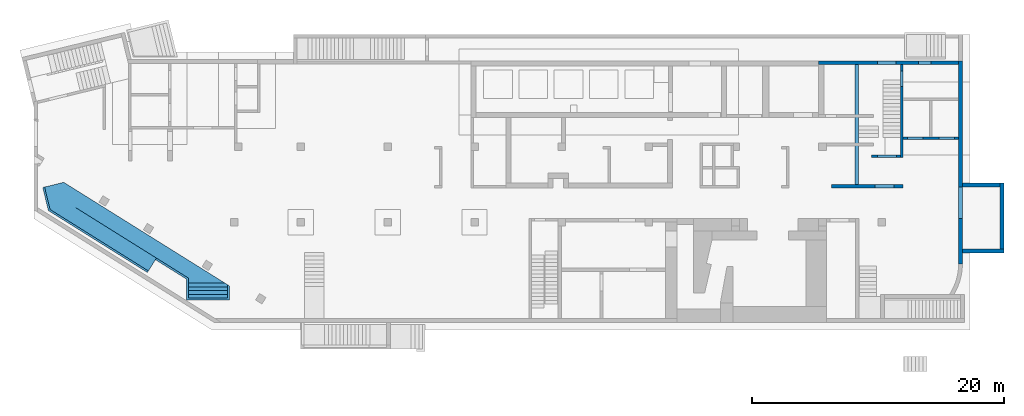
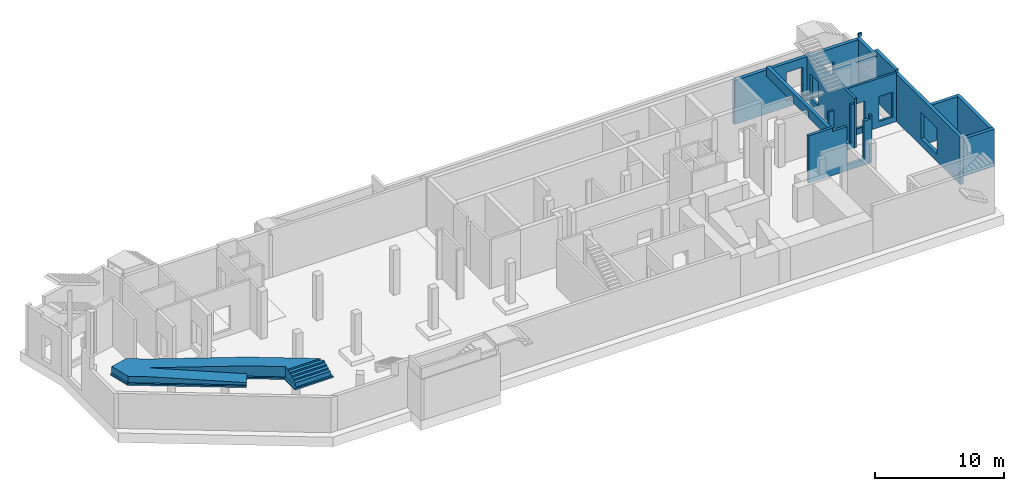
# One storey, part 8 of 9: 10 walls, 1 stair, 6 openings.
"""IFC4 building model written with IfcOpenShell, lengths in millimetres."""

from ifc_helpers import new_model, entity, si_unit, converted_unit, derived_unit, direction, frame, origin, place, context, subcontext, project, spatial, indexed_curve, outline, extrude, polygons, material, type_object, element, save


model = new_model("IFC4")

# Units and contexts
model_context = context("Model", 3, precision=0.01, world=origin(), true_north=direction((6.12303176911189e-17, 1.0)))
plan_context = context("Plan", 3, precision=0.01, world=origin(), true_north=direction((6.12303176911189e-17, 1.0)))
body_context = subcontext(model_context, "Body", "Model", "MODEL_VIEW")
ifc_project = project(units=[si_unit("LENGTHUNIT", "METRE", prefix="MILLI"), si_unit("AREAUNIT", "SQUARE_METRE"), si_unit("VOLUMEUNIT", "CUBIC_METRE"), converted_unit("PLANEANGLEUNIT", "DEGREE", entity("IfcRatioMeasure", 0.0174532925199433), si_unit("PLANEANGLEUNIT", "RADIAN"), dimensions=[0, 0, 0, 0, 0, 0, 0]), si_unit("MASSUNIT", "GRAM", prefix="KILO"), derived_unit("MASSDENSITYUNIT", [(si_unit("MASSUNIT", "GRAM", prefix="KILO"), 1), (si_unit("LENGTHUNIT", "METRE"), -3)]), derived_unit("MOMENTOFINERTIAUNIT", [(si_unit("LENGTHUNIT", "METRE"), 4)]), si_unit("TIMEUNIT", "SECOND"), si_unit("FREQUENCYUNIT", "HERTZ"), si_unit("THERMODYNAMICTEMPERATUREUNIT", "DEGREE_CELSIUS"), derived_unit("THERMALTRANSMITTANCEUNIT", [(si_unit("MASSUNIT", "GRAM", prefix="KILO"), 1), (si_unit("THERMODYNAMICTEMPERATUREUNIT", "KELVIN"), -1), (si_unit("TIMEUNIT", "SECOND"), -3)]), derived_unit("VOLUMETRICFLOWRATEUNIT", [(si_unit("LENGTHUNIT", "METRE"), 3), (si_unit("TIMEUNIT", "SECOND"), -1)]), derived_unit("MASSFLOWRATEUNIT", [(si_unit("MASSUNIT", "GRAM", prefix="KILO"), 1), (si_unit("TIMEUNIT", "SECOND"), -1)]), derived_unit("ROTATIONALFREQUENCYUNIT", [(si_unit("TIMEUNIT", "SECOND"), -1)]), si_unit("ELECTRICCURRENTUNIT", "AMPERE"), si_unit("ELECTRICVOLTAGEUNIT", "VOLT"), si_unit("POWERUNIT", "WATT"), si_unit("FORCEUNIT", "NEWTON", prefix="KILO"), si_unit("ILLUMINANCEUNIT", "LUX"), si_unit("LUMINOUSFLUXUNIT", "LUMEN"), si_unit("LUMINOUSINTENSITYUNIT", "CANDELA"), derived_unit("USERDEFINED", [(si_unit("MASSUNIT", "GRAM", prefix="KILO"), -1), (si_unit("LENGTHUNIT", "METRE"), -2), (si_unit("TIMEUNIT", "SECOND"), 3), (si_unit("LUMINOUSFLUXUNIT", "LUMEN"), 1)]), derived_unit("LINEARVELOCITYUNIT", [(si_unit("LENGTHUNIT", "METRE"), 1), (si_unit("TIMEUNIT", "SECOND"), -1)]), si_unit("PRESSUREUNIT", "PASCAL"), derived_unit("USERDEFINED", [(si_unit("LENGTHUNIT", "METRE"), -2), (si_unit("MASSUNIT", "GRAM", prefix="KILO"), 1), (si_unit("TIMEUNIT", "SECOND"), -2)]), derived_unit("LINEARFORCEUNIT", [(si_unit("MASSUNIT", "GRAM", prefix="KILO"), 1), (si_unit("LENGTHUNIT", "METRE"), 1), (si_unit("TIMEUNIT", "SECOND"), -2), (si_unit("LENGTHUNIT", "METRE"), -1)]), derived_unit("PLANARFORCEUNIT", [(si_unit("MASSUNIT", "GRAM", prefix="KILO"), 1), (si_unit("LENGTHUNIT", "METRE"), 1), (si_unit("TIMEUNIT", "SECOND"), -2), (si_unit("LENGTHUNIT", "METRE"), -2)])], contexts=[model_context, plan_context])

# Site, building, storey
site_placement = place(None, origin())
site = spatial("IfcSite", under=ifc_project, at=site_placement, CompositionType="ELEMENT")
building_placement = place(site_placement, origin())
building = spatial("IfcBuilding", under=site, at=building_placement, CompositionType="ELEMENT")
storey_placement = place(building_placement, frame((0.0, 0.0, -4900.0)))
storey = spatial("IfcBuildingStorey", under=building, at=storey_placement, CompositionType="ELEMENT", Elevation=-4900.0)

# Wall, openings
ifc_material_1 = material()
wall_type_1 = type_object("IfcWallType", Name=":ADSK_ 25_200", PredefinedType="STANDARD")
wall_1_placement = place(storey_placement, frame((68970.0, 14370.0, 0.0)))
wall_1 = element("IfcWall", 1, at=wall_1_placement, inside=storey, type_object=wall_type_1, material=ifc_material_1, Name=":ADSK_ 25_200", ObjectType=":ADSK_ 25_200", PredefinedType="NOTDEFINED", context=body_context, shape_type="Tessellation", body=[
    polygons([(2.81053507844076e-12, -100.000000000001, 0.0), (4399.99999999999, -99.9999999999989, 0.0), (4399.99999999999, -99.9999999999989, 4650.0), (2.81053507844076e-12, -100.000000000001, 4650.0), (329.999999999988, -100.000000000003, 2919.99999999804), (1569.99999999999, -100.000000000001, 2919.99999999804), (1569.99999999999, -100.000000000001, 550.0), (329.999999999988, -100.000000000003, 550.0), (2829.99999999998, -100.000000000001, 2919.99999999804), (4069.99999999998, -100.000000000001, 2919.99999999804), (4069.99999999998, -100.000000000001, 550.0), (2829.99999999998, -100.000000000001, 550.0), (4399.99999999999, 99.9999999999989, 0.0), (2.12143781434178e-12, 99.9999999999968, 0.0), (2.12143781434178e-12, 99.9999999999968, 4650.0), (2099.99999999998, 99.9999999999989, 4650.0), (2299.99999999997, 99.9999999999968, 4650.0), (4399.99999999999, 99.9999999999989, 4650.0), (1569.99999999999, 99.9999999999989, 2919.99999999804), (329.999999999996, 99.9999999999968, 2919.99999999804), (329.999999999996, 99.9999999999968, 550.0), (1569.99999999999, 99.9999999999989, 550.0), (4069.99999999998, 99.9999999999989, 2919.99999999804), (2829.99999999998, 99.9999999999968, 2919.99999999804), (2829.99999999998, 99.9999999999968, 550.0), (4069.99999999998, 99.9999999999989, 550.0)], [[[1, 2, 3, 4], [5, 6, 7, 8], [9, 10, 11, 12]], [[13, 14, 15, 16, 17, 18], [19, 20, 21, 22], [23, 24, 25, 26]], [[2, 1, 14, 13]], [[4, 3, 18, 17, 16, 15]], [[3, 2, 13, 18]], [[1, 4, 15, 14]], [[5, 20, 19, 6]], [[6, 19, 22, 7]], [[7, 22, 21, 8]], [[20, 5, 8, 21]], [[23, 10, 9, 24]], [[12, 25, 24, 9]], [[25, 12, 11, 26]], [[26, 11, 10, 23]]], closed=True),
])
placement_1 = place(wall_1_placement, frame((-68970.0, -14370.0, 0.0)))
element("IfcOpeningElement", 2, at=placement_1, cuts=wall_1, Name=":ADSK_ 25_200", PredefinedType="OPENING", context=body_context, shape_type="SweptSolid", body=[
    extrude(outline(indexed_curve([(-619.999999999998, -1184.99999999902), (620.000000000006, -1184.99999999902), (620.000000000006, 1184.99999999902), (-619.999999999998, 1184.99999999902), (-619.999999999998, -1184.99999999902)], self_intersect=False)), frame((69920.0, 14170.0, 1735.0), z_axis=(0.0, 1.0, 0.0), x_axis=(1.0, 0.0, 0.0)), (0.0, 0.0, 1.0), 400.000000001943),
])
element("IfcOpeningElement", 3, at=placement_1, cuts=wall_1, Name=":ADSK_ 25_200", PredefinedType="OPENING", context=body_context, shape_type="SweptSolid", body=[
    extrude(outline(indexed_curve([(-1184.99999999902, -619.999999999998), (1184.99999999902, -619.999999999998), (1184.99999999902, 619.999999999998), (-1184.99999999902, 619.999999999998), (-1184.99999999902, -619.999999999998)], self_intersect=False)), frame((72420.0, 14170.0, 1735.0), z_axis=(0.0, 1.0, 0.0), x_axis=(0.0, 0.0, -1.0)), (0.0, 0.0, 1.0), 400.000000001943),
])

# Wall, opening
wall_2_placement = place(storey_placement, frame((68870.0, 20200.0, 0.0), z_axis=(0.0, 0.0, 1.0), x_axis=(0.0, -1.0, 0.0)))
wall_2 = element("IfcWall", 4, at=wall_2_placement, inside=storey, type_object=wall_type_1, material=ifc_material_1, Name=":ADSK_ 25_200", ObjectType=":ADSK_ 25_200", PredefinedType="NOTDEFINED", context=body_context, shape_type="Tessellation", body=[
    polygons([(0.0, -100.000000000003, 0.0), (7169.99999999999, -99.9999999999902, 0.0), (7369.99999999999, -99.9999999999983, 0.0), (7369.99999999999, -99.9999999999983, 4170.0), (7369.99999999999, -99.9999999999983, 4650.0), (0.0, -100.000000000003, 4650.0), (0.0, -100.000000000003, 4420.0), (2830.00000000002, -100.000000000012, 4420.0), (2830.00000000002, -100.000000000012, 4170.0), (0.0, -100.000000000003, 4170.0), (500.000000000003, -100.000000000001, 2829.99999999805), (1750.0, -99.9999999999977, 2829.99999999804), (1750.0, -99.9999999999977, 550.0), (500.000000000003, -100.000000000001, 550.0), (7369.99999999999, 99.9999999999996, 0.0), (5930.00000000002, 100.000000000004, 0.0), (5730.00000000002, 100.000000000003, 0.0), (2830.00000000051, 100.000000000003, 0.0), (2630.00000000051, 100.000000000003, 0.0), (-4.33146851719357e-12, 100.000000000004, 0.0), (-4.33146851719357e-12, 100.000000000004, 4170.0), (2630.00000000051, 100.000000000003, 4170.0), (2830.00000000002, 100.000000000012, 4170.0), (2830.00000000002, 100.000000000012, 4420.0), (2630.00000000051, 100.000000000003, 4420.0), (-4.33146851719357e-12, 100.000000000004, 4420.0), (-4.33146851719357e-12, 100.000000000004, 4650.0), (2630.00000000051, 100.000000000003, 4650.0), (2830.00000000051, 100.000000000003, 4650.0), (5730.00000000002, 100.000000000003, 4650.0), (5930.00000000002, 100.000000000004, 4650.0), (7369.99999999999, 99.9999999999996, 4650.0), (1749.99999999999, 100.000000000009, 2829.99999999804), (499.999999999999, 100.000000000005, 2829.99999999805), (499.999999999999, 100.000000000005, 550.0), (1749.99999999999, 100.000000000009, 550.0)], [[[1, 2, 3, 4, 5, 6, 7, 8, 9, 10], [11, 12, 13, 14]], [[15, 16, 17, 18, 19, 20, 21, 22, 23, 24, 25, 26, 27, 28, 29, 30, 31, 32], [33, 34, 35, 36]], [[3, 2, 1, 20, 19, 18, 17, 16, 15]], [[6, 5, 32, 31, 30, 29, 28, 27]], [[5, 4, 3, 15, 32]], [[20, 1, 10, 21]], [[11, 34, 33, 12]], [[36, 13, 12, 33]], [[13, 36, 35, 14]], [[14, 35, 34, 11]], [[9, 23, 22, 21, 10]], [[24, 8, 7, 26, 25]], [[23, 9, 8, 24]], [[6, 27, 26, 7]]], closed=True),
])
opening_3_placement = place(wall_2_placement, frame((20200.0, -68870.0, 0.0), z_axis=(0.0, 0.0, 1.0), x_axis=(0.0, 1.0, 0.0)))
element("IfcOpeningElement", 5, at=opening_3_placement, cuts=wall_2, Name=":ADSK_ 25_200", PredefinedType="OPENING", context=body_context, shape_type="SweptSolid", body=[
    extrude(outline(indexed_curve([(-624.999999999999, -1139.99999999902), (624.999999999999, -1139.99999999902), (624.999999999999, 1139.99999999902), (-624.999999999999, 1139.99999999902), (-624.999999999999, -1139.99999999902)], self_intersect=False)), frame((68670.0, 19075.0, 1690.0), z_axis=(1.0, 0.0, 0.0), x_axis=(0.0, -1.0, 0.0)), (0.0, 0.0, 1.0), 400.000000001936),
])

wall_3_placement = place(storey_placement, frame((68770.0, 12930.0, 0.0), z_axis=(0.0, 0.0, 1.0), x_axis=(-1.0, 0.0, 0.0)))
wall_3 = element("IfcWall", 6, at=wall_3_placement, inside=storey, type_object=wall_type_1, material=ifc_material_1, Name=":ADSK_ 25_200", ObjectType=":ADSK_ 25_200", PredefinedType="NOTDEFINED", context=body_context, shape_type="Tessellation", body=[
    polygons([(9.8127816513605e-13, -99.9999999999989, 0.0), (2300.00000000003, -99.9999999999989, 0.0), (2300.00000000003, -99.9999999999989, 4170.0), (1830.00000000004, -99.9999999999989, 4170.0), (1830.00000000004, -99.9999999999989, 550.0), (330.00000000003, -99.9999999999968, 550.0), (330.00000000003, -99.9999999999968, 4170.0), (9.8127816513605e-13, -99.9999999999989, 4170.0), (2300.00000000003, 100.000000000001, 0.0), (8.96430781706574e-12, 100.000000000001, 0.0), (8.96430781706574e-12, 100.000000000001, 4170.0), (330.000000000029, 100.000000000003, 4170.0), (330.000000000029, 100.000000000003, 550.0), (1830.00000000003, 100.000000000001, 550.0), (1830.00000000003, 100.000000000001, 4170.0), (2300.00000000003, 100.000000000001, 4170.0)], [[[1, 2, 3, 4, 5, 6, 7, 8]], [[9, 10, 11, 12, 13, 14, 15, 16]], [[2, 1, 10, 9]], [[3, 2, 9, 16]], [[3, 16, 15, 4]], [[1, 8, 11, 10]], [[14, 5, 4, 15]], [[5, 14, 13, 6]], [[6, 13, 12, 7]], [[11, 8, 7, 12]]], closed=True),
])
opening_4_placement = place(wall_3_placement, frame((68770.0, 12930.0, 0.0), z_axis=(0.0, 0.0, 1.0), x_axis=(-1.0, 0.0, 0.0)))
element("IfcOpeningElement", 7, at=opening_4_placement, cuts=wall_3, Name=":ADSK_ 25_200", PredefinedType="OPENING", context=body_context, shape_type="SweptSolid", body=[
    extrude(outline(indexed_curve([(-749.999999999994, -1809.99999999902), (750.000000000003, -1809.99999999902), (750.000000000003, 1809.99999999902), (-749.999999999994, 1809.99999999902), (-749.999999999994, -1809.99999999902)], self_intersect=False)), frame((67690.0, 13130.0, 2360.0), z_axis=(0.0, -1.0, 0.0), x_axis=(-1.0, 0.0, 0.0)), (0.0, 0.0, 1.0), 400.000000001943),
])

# Walls
wall_type_2 = type_object("IfcWallType", Name=":ADSK_ 25_300", PredefinedType="STANDARD")
wall_4_placement = place(storey_placement, frame((73520.0, 4400.0, 0.0), z_axis=(0.0, 0.0, 1.0), x_axis=(0.0, 1.0, 0.0)))
element("IfcWall", 8, at=wall_4_placement, inside=storey, type_object=wall_type_2, material=ifc_material_1, Name=":ADSK_ 25_300", ObjectType=":ADSK_ 25_300", PredefinedType="NOTDEFINED", context=body_context, shape_type="Tessellation", body=[
    polygons([(0.0, -149.999999999999, 0.0), (875.000000000547, -149.999999999997, 0.0), (1175.00000000055, -150.000000000005, 0.0), (6100.00000000051, -150.000000000002, 0.0), (6400.00000000052, -150.000000000001, 0.0), (16100.0000000005, -150.000000000004, 0.0), (16100.0000000005, -150.000000000004, 3300.0), (16100.0000000005, -150.000000000004, 3550.0), (16100.0000000005, -150.000000000004, 4170.0), (12970.0000000005, -150.000000000003, 4170.0), (12970.0000000005, -150.000000000003, 4420.0), (13275.0000000005, -150.000000000002, 4420.0), (13275.0000000005, -150.000000000002, 4750.0), (10070.0000000005, -150.000000000009, 4750.0), (10070.0000000005, -150.000000000009, 4500.0), (0.0, -149.999999999999, 4500.0), (3600.00000000052, -149.999999999999, 3199.99999999804), (6100.00000000051, -150.000000000002, 3199.99999999804), (6100.00000000051, -150.000000000002, 700.0), (3600.00000000052, -149.999999999999, 700.0), (16100.0000000005, 149.999999999997, 0.0), (15800.0000000005, 149.999999999997, 0.0), (13170.0, 149.999999999999, 0.0), (12970.0, 149.999999999998, 0.0), (10070.0000000005, 150.0, 0.0), (9870.00000000053, 150.0, 0.0), (0.0, 150.000000000002, 0.0), (0.0, 150.000000000002, 4500.0), (10070.0000000005, 149.999999999992, 4500.0), (10070.0000000005, 149.999999999992, 4750.0), (13275.0000000005, 149.999999999999, 4750.0), (13275.0000000005, 149.999999999999, 4420.0), (13170.0, 149.999999999999, 4420.0), (12970.0000000005, 149.999999999998, 4420.0), (12970.0000000005, 149.999999999998, 4170.0), (13170.0, 149.999999999999, 4170.0), (15800.0000000005, 149.999999999997, 4170.0), (16100.0000000005, 149.999999999997, 4170.0), (16100.0000000005, 149.999999999997, 3300.0), (6100.00000000051, 149.999999999999, 3199.99999999804), (3600.00000000052, 150.000000000002, 3199.99999999804), (3600.00000000052, 150.000000000002, 700.0), (6100.00000000051, 149.999999999999, 700.0), (13275.0000000006, -49.99999999999, 4750.0)], [[[1, 2, 3, 4, 5, 6, 7, 8, 9, 10, 11, 12, 13, 14, 15, 16], [17, 18, 19, 20]], [[21, 22, 23, 24, 25, 26, 27, 28, 29, 30, 31, 32, 33, 34, 35, 36, 37, 38, 39], [40, 41, 42, 43]], [[6, 5, 4, 3, 2, 1, 27, 26, 25, 24, 23, 22, 21]], [[27, 1, 16, 28]], [[35, 10, 9, 38, 37, 36]], [[10, 35, 34, 11]], [[17, 41, 40, 18]], [[43, 19, 18, 40]], [[19, 43, 42, 20]], [[20, 42, 41, 17]], [[15, 29, 28, 16]], [[29, 15, 14, 30]], [[6, 21, 39, 38, 9, 8, 7]], [[13, 12, 32, 31, 44]], [[11, 34, 33, 32, 12]], [[13, 44, 31, 30, 14]]], closed=True),
    polygons([(15900.0000000005, -150.000000000004, 4750.0), (15900.0000000005, 149.999999999997, 4750.0), (15775.0000000006, 149.999999999997, 4750.0), (15775.0000000006, -49.9999999999927, 4750.0), (15775.0000000006, -150.000000000005, 4750.0), (15900.0000000005, -150.000000000004, 4420.0), (15775.0000000006, -150.000000000005, 4420.0), (15775.0000000006, 149.999999999997, 4420.0), (15900.0000000005, 149.999999999997, 4420.0)], [[[1, 2, 3, 4, 5]], [[6, 7, 8, 9]], [[2, 1, 6, 9]], [[7, 5, 4, 3, 8]], [[2, 9, 8, 3]], [[7, 6, 1, 5]]], closed=True),
])
wall_5_placement = place(storey_placement, frame((73670.0, 5425.0, 0.0)))
element("IfcWall", 9, at=wall_5_placement, inside=storey, type_object=wall_type_2, material=ifc_material_1, Name=":ADSK_ 25_300", ObjectType=":ADSK_ 25_300", PredefinedType="NOTDEFINED", context=body_context, shape_type="Tessellation", body=[
    polygons([(4.01064381973369e-13, -149.999999999999, 0.0), (600.000000000003, -149.999999999999, 0.0), (3300.0, -149.999999999999, 0.0), (3300.0, -149.999999999999, 3500.0), (4.01064381973369e-13, -149.999999999999, 3500.0), (8.10145285698416e-12, 150.000000000001, 0.0), (8.10145285698416e-12, 150.000000000001, 3500.0), (3000.0, 150.000000000001, 3500.0), (3300.00000000002, 150.000000000001, 3500.0), (3299.99999999999, 150.000000000001, 0.0), (3000.0, 150.000000000001, 0.0)], [[[1, 2, 3, 4, 5]], [[6, 7, 8, 9, 10, 11]], [[3, 2, 1, 6, 11, 10]], [[4, 3, 10, 9]], [[1, 5, 7, 6]], [[5, 4, 9, 8, 7]]], closed=True),
])
wall_6_placement = place(storey_placement, frame((76820.0, 5575.0, 0.0), z_axis=(0.0, 0.0, 1.0), x_axis=(0.0, 1.0, 0.0)))
element("IfcWall", 10, at=wall_6_placement, inside=storey, type_object=wall_type_2, material=ifc_material_1, Name=":ADSK_ 25_300", ObjectType=":ADSK_ 25_300", PredefinedType="NOTDEFINED", context=body_context, shape_type="Tessellation", body=[
    polygons([(0.0, -149.999999999992, 0.0), (5224.99999999998, -150.000000000001, 0.0), (5224.99999999998, -150.000000000001, 3500.0), (0.0, -149.999999999992, 3500.0), (1.08286712929839e-12, 150.000000000009, 0.0), (1.08286712929839e-12, 150.000000000009, 3500.0), (4924.99999999998, 150.0, 3500.0), (5225.0, 150.0, 3500.0), (5224.99999999998, 150.0, 0.0), (4924.99999999998, 150.0, 0.0)], [[[1, 2, 3, 4]], [[5, 6, 7, 8, 9, 10]], [[2, 1, 5, 10, 9]], [[1, 4, 6, 5]], [[3, 2, 9, 8]], [[4, 3, 8, 7, 6]]], closed=True),
])
wall_7_placement = place(storey_placement, frame((76670.0, 10650.0, 0.0), z_axis=(0.0, 0.0, 1.0), x_axis=(-1.0, 0.0, 0.0)))
element("IfcWall", 11, at=wall_7_placement, inside=storey, type_object=wall_type_2, material=ifc_material_1, Name=":ADSK_ 25_300", ObjectType=":ADSK_ 25_300", PredefinedType="NOTDEFINED", context=body_context, shape_type="Tessellation", body=[
    polygons([(0.0, -150.000000000001, 0.0), (2400.0, -150.000000000001, 0.0), (2999.99999999999, -150.000000000001, 0.0), (2999.99999999999, -150.000000000001, 3500.0), (0.0, -150.000000000001, 3500.0), (0.0, 150.000000000001, 0.0), (0.0, 150.000000000001, 3500.0), (2999.99999999999, 150.000000000001, 3500.0), (2999.99999999999, 150.000000000001, 3199.99999999804), (2999.99999999999, 150.000000000001, 700.0), (2999.99999999999, 150.000000000001, 0.0)], [[[1, 2, 3, 4, 5]], [[6, 7, 8, 9, 10, 11]], [[3, 2, 1, 6, 11]], [[1, 5, 7, 6]], [[4, 3, 11, 10, 9, 8]], [[5, 4, 8, 7]]], closed=True),
])

# Wall, openings
wall_8_placement = place(storey_placement, frame((73370.0, 20350.0, 0.0), z_axis=(0.0, 0.0, 1.0), x_axis=(-1.0, 0.0, 0.0)))
wall_8 = element("IfcWall", 12, at=wall_8_placement, inside=storey, type_object=wall_type_2, material=ifc_material_1, Name=":ADSK_ 25_300", ObjectType=":ADSK_ 25_300", PredefinedType="NOTDEFINED", context=body_context, shape_type="Tessellation", body=[
    polygons([(-2.63247301876675e-12, -150.000000000001, 0.0), (11100.0, -150.000000000001, 0.0), (11100.0, -150.000000000001, 4170.0), (10700.0, -150.000000000005, 4170.0), (-2.63247301876675e-12, -150.000000000001, 4170.0), (2195.00000000001, -150.000000000005, 2829.99999999804), (3195.00000000001, -150.000000000005, 2829.99999999805), (3195.00000000001, -150.000000000005, 550.0), (2195.00000000001, -150.000000000005, 550.0), (4950.00000000001, -150.000000000005, 3299.99999999804), (6450.00000000001, -150.000000000005, 3299.99999999805), (6450.00000000001, -150.000000000005, 550.0), (4950.00000000001, -150.000000000005, 550.0), (11100.0, 150.000000000001, 0.0), (10700.0, 149.999999999996, 0.0), (4599.99999999997, 149.999999999996, 0.0), (4399.99999999997, 149.999999999996, 0.0), (-4.49556941830264e-12, 150.000000000001, 0.0), (-4.49556941830264e-12, 150.000000000001, 4170.0), (4399.99999999997, 149.999999999996, 4170.0), (4599.99999999997, 149.999999999996, 4170.0), (10700.0, 149.999999999996, 4170.0), (11100.0, 150.000000000001, 4170.0), (6450.00000000002, 149.999999999996, 3299.99999999805), (4950.00000000001, 149.999999999996, 3299.99999999804), (4950.00000000001, 149.999999999996, 550.0), (6450.00000000002, 149.999999999996, 550.0), (3195.00000000001, 149.999999999996, 2829.99999999805), (2195.00000000001, 149.999999999996, 2829.99999999804), (2195.00000000001, 149.999999999996, 550.0), (3195.00000000001, 149.999999999996, 550.0)], [[[1, 2, 3, 4, 5], [6, 7, 8, 9], [10, 11, 12, 13]], [[14, 15, 16, 17, 18, 19, 20, 21, 22, 23], [24, 25, 26, 27], [28, 29, 30, 31]], [[2, 1, 18, 17, 16, 15, 14]], [[5, 4, 3, 23, 22, 21, 20, 19]], [[3, 2, 14, 23]], [[24, 11, 10, 25]], [[25, 10, 13, 26]], [[26, 13, 12, 27]], [[11, 24, 27, 12]], [[28, 7, 6, 29]], [[9, 30, 29, 6]], [[30, 9, 8, 31]], [[31, 8, 7, 28]], [[5, 19, 18, 1]]], closed=True),
])
placement_2 = place(wall_8_placement, frame((73370.0, 20350.0, 0.0), z_axis=(0.0, 0.0, 1.0), x_axis=(-1.0, 0.0, 0.0)))
element("IfcOpeningElement", 13, at=placement_2, cuts=wall_8, Name=":ADSK_ 25_300", PredefinedType="OPENING", context=body_context, shape_type="SweptSolid", body=[
    extrude(outline(indexed_curve([(-1374.99999999902, -749.999999999994), (1374.99999999902, -749.999999999994), (1374.99999999902, 750.000000000003), (-1374.99999999902, 750.000000000003), (-1374.99999999902, -749.999999999994)], self_intersect=False)), frame((67670.0, 20600.0, 1925.0), z_axis=(0.0, -1.0, 0.0), x_axis=(0.0, 0.0, -1.0)), (0.0, 0.0, 1.0), 500.000000001944),
])
element("IfcOpeningElement", 14, at=placement_2, cuts=wall_8, Name=":ADSK_ 25_300", PredefinedType="OPENING", context=body_context, shape_type="SweptSolid", body=[
    extrude(outline(indexed_curve([(-1139.99999999902, -499.999999999999), (1139.99999999902, -499.999999999999), (1139.99999999902, 499.999999999999), (-1139.99999999902, 499.999999999999), (-1139.99999999902, -499.999999999999)], self_intersect=False)), frame((70675.0, 20600.0, 1690.0), z_axis=(0.0, -1.0, 0.0), x_axis=(0.0, 0.0, -1.0)), (0.0, 0.0, 1.0), 500.000000001939),
])

# Walls
wall_9_placement = place(storey_placement, frame((65280.0, 10675.0, 3600.0), z_axis=(0.0, 0.0, 1.0), x_axis=(0.0, 1.0, 0.0)))
element("IfcWall", 15, at=wall_9_placement, inside=storey, type_object=wall_type_2, material=ifc_material_1, Name=":ADSK_ 25_300", ObjectType=":ADSK_ 25_300", PredefinedType="NOTDEFINED", context=body_context, shape_type="Tessellation", body=[
    polygons([(0.0, -150.000000000001, 900.0), (0.0, -150.000000000001, 570.0), (0.0, -150.000000000001, 0.0), (3074.99922635569, -150.000000000001, 0.0), (3074.99922635569, -150.000000000001, 570.0), (3324.99922635569, -150.000000000001, 570.0), (3324.99922635569, -150.000000000001, 0.0), (5324.99922635551, -150.000000000001, 0.0), (5324.99922635551, -150.000000000001, 570.0), (5574.99922635551, -150.000000000001, 570.0), (5574.99922635551, -150.000000000001, 0.0), (9524.9992263555, -150.000000000001, 0.0), (9524.9992263555, -150.000000000009, 900.0), (3794.99922635547, -150.000000000001, 900.0), (2.16573425859679e-12, 150.000000000001, 900.0), (9524.9992263555, 150.000000000001, 900.0), (9524.9992263555, 150.000000000001, 0.0), (5574.99922635551, 150.000000000001, 0.0), (5574.99922635551, 150.000000000001, 570.0), (5324.99922635551, 150.000000000001, 570.0), (5324.99922635551, 150.000000000001, 0.0), (3324.99922635569, 150.000000000001, 0.0), (3324.99922635569, 150.000000000001, 570.0), (3074.9992263557, 150.000000000001, 570.0), (3074.99922635569, 150.000000000001, 0.0), (2.16573425859679e-12, 150.000000000001, 0.0)], [[[1, 2, 3, 4, 5, 6, 7, 8, 9, 10, 11, 12, 13, 14]], [[15, 16, 17, 18, 19, 20, 21, 22, 23, 24, 25, 26]], [[3, 26, 25, 4]], [[3, 2, 1, 15, 26]], [[16, 15, 1, 14, 13]], [[13, 12, 17, 16]], [[5, 4, 25, 24]], [[7, 6, 23, 22]], [[10, 19, 18, 11]], [[20, 9, 8, 21]], [[19, 10, 9, 20]], [[5, 24, 23, 6]], [[7, 22, 21, 8]], [[17, 12, 11, 18]]], closed=True),
])
wall_type_3 = type_object("IfcWallType", Name=":ADSK_ 25_250", PredefinedType="STANDARD")
wall_10_placement = place(storey_placement, frame((63285.0, 10550.0, 0.0)))
element("IfcWall", 16, at=wall_10_placement, inside=storey, type_object=wall_type_3, material=ifc_material_1, Name=":ADSK_ 25_250", ObjectType=":ADSK_ 25_250", PredefinedType="NOTDEFINED", context=body_context, shape_type="Tessellation", body=[
    polygons([(7.89039547462626e-12, -125.0, 0.0), (5685.0, -125.0, 0.0), (5685.0, -125.0, 4500.0), (5484.99999999999, -125.0, 4500.0), (5484.99999999999, -125.000257881502, 4170.0), (4945.00000000001, -125.0, 4169.99999999935), (4945.00000000001, -125.0, 550.0), (3445.0, -125.0, 550.0), (3445.0, -125.0, 4169.99999999935), (2145.00000000002, -125.000257881506, 4170.0), (2145.00000000002, -125.0, 4500.0), (7.89039547462626e-12, -125.0, 4500.0), (5685.0, 125.0, 0.0), (7.04089212457092e-12, 125.0, 0.0), (7.04089212457092e-12, 125.0, 4500.0), (1844.99999999999, 125.0, 4500.0), (2145.00000000002, 125.000000000002, 4500.0), (2145.00000000002, 125.0, 4170.0), (3445.0, 125.0, 4169.99999999935), (3445.0, 125.0, 550.0), (4945.00000000002, 125.0, 550.0), (4945.00000000001, 125.0, 4169.99999999935), (5484.99999999999, 125.0, 4170.0), (5484.99999999999, 125.0, 4500.0), (5685.0, 125.0, 4500.0)], [[[1, 2, 3, 4, 5, 6, 7, 8, 9, 10, 11, 12]], [[13, 14, 15, 16, 17, 18, 19, 20, 21, 22, 23, 24, 25]], [[2, 1, 14, 13]], [[3, 2, 13, 25]], [[3, 25, 24, 4]], [[1, 12, 15, 14]], [[5, 23, 22, 6]], [[10, 18, 17, 11]], [[23, 5, 4, 24]], [[8, 20, 19, 9]], [[20, 8, 7, 21]], [[21, 7, 6, 22]], [[18, 10, 9, 19]], [[15, 12, 11, 17, 16]]], closed=True),
])

# Stair
ifc_material_2 = material()
stair_type = type_object("IfcStairType", Name="13: 13", PredefinedType="HALF_TURN_STAIR")
stair_placement = place(storey_placement, frame((706.27, 1525.0, 3730.0)))
element("IfcStair", 17, at=stair_placement, inside=storey, type_object=stair_type, material=ifc_material_2, Name="13: 13", ObjectType="13: 13", PredefinedType="HALF_TURN_STAIR", context=body_context, shape_type="Tessellation", body=[
    polygons([(579.732808887634, 7186.00869393675, 750.000000000001), (1851.81192455399, 6391.1409543187, 750.000000000001), (2487.70611624843, 7408.80424685179, 750.0), (3123.60030794287, 8426.46753938488, 750.000000000001), (1666.69514343611, 9336.82515840979, 750.000000000001), (145.750531009357, 8966.00181001227, 750.000000000001), (1931.2986985158, 6518.34886588534, 600.000000000001), (711.000745367871, 7280.86077550907, 600.000000000001), (327.012520496049, 8855.80157785586, 600.000000000001), (1640.81431872975, 9176.12118579633, 600.000000000001), (3044.11353398106, 8299.25962781825, 600.000000000001), (579.732808887639, 7186.00869393675, 150.000000000001), (8381.8180516413, 2310.81989094609, 150.000000000001), (8381.8180516413, 2310.81989094609, 369.999999999997), (1666.69514343611, 9336.82515840979, 0.0), (4.06075173486897e-13, 8930.55058390988, 0.0), (4.06075173486897e-13, 8930.55058390988, 150.000000000001), (145.732808887646, 8966.074497899, 150.000000000001), (448.464872407401, 7091.15661236443, 150.000000000001), (8302.33127767949, 2183.61197937946, 150.000000000001), (2281.01143071999, 7361.08310924696, 0.0), (2519.4717526054, 7742.70684394687, 0.0), (11843.7328088876, 1916.37558975191, 0.0), (11843.7328088876, 450.000000000011, 0.0), (14373.7328088876, 450.000000000002, 0.0), (14373.7328088876, 1072.10840588886, 0.0), (1648.45406369317, 9023.58990388021, 0.0), (508.274509982748, 8745.60134569946, 0.0), (842.268681848117, 7375.71285708139, 0.0), (8540.79159956491, 2565.23571407936, 0.0), (8302.33127767949, 2183.61197937946, 0.0), (448.464872407401, 7091.15661236443, 0.0), (14823.7328088876, 1115.55600902313, 0.0), (14823.7328088876, 8.12150346973795e-13, 0.0), (11393.7328088876, 1.21822552046069e-11, 0.0), (11393.7328088876, 1666.93393689869, 0.0), (2281.01143071999, 7361.08310924696, 150.000000000001), (11393.7328088876, 1666.93393689869, 150.000000000001), (2519.4717526054, 7742.70684394687, 150.000000000001), (11843.7328088876, 1916.37558975191, 150.000000000001), (9017.71224333574, 3328.48318347918, 1120.0), (9017.71224333574, 3328.48318347918, 369.999999999997), (9017.71224333574, 3328.48318347918, 219.817449587824), (2487.70611624843, 7408.80424685179, 599.817449587827), (2487.70611624843, 7408.80424685179, 149.999999999984), (11543.7328088876, 1750.08115451642, 150.000000000001), (11543.7328088876, 1750.08115451643, 1120.0), (11693.7328088876, 1833.22837213415, 150.000000000001), (2567.19289021024, 7536.01215841843, 149.999999999984), (2567.19289021024, 7536.01215841843, 599.826925620747), (9097.19901729755, 3455.69109504581, 969.826925620748), (9097.19901729755, 3455.69109504581, 970.0), (11693.7328088876, 1833.22837213415, 970.0), (1931.2986985158, 6518.34886588534, 599.817449587827), (3044.11353398106, 8299.25962781825, 599.826925620767), (9653.60643503017, 4346.14647601226, 1120.0), (14448.5366726619, 1350.0, 1120.0), (14448.5366726619, 1350.0, 980.0), (14673.7328088876, 1209.28458256413, 979.999999999992), (14673.7328088876, 1209.28458256413, 150.000000000001), (14823.7328088876, 1115.55600902313, 150.0), (14448.5366726619, 1350.0, 814.470546427522), (14448.5366726619, 1350.0, 150.000000000001), (14523.7328088876, 1303.01315610513, 150.000000000001), (14523.7328088876, 1303.01315610513, 792.543352609913), (9574.11966106838, 4218.93856444562, 969.826925620765), (1640.81431872975, 9176.12118579633, 150.000000000001), (14165.4707123952, 1350.0, 150.000000000001), (14165.4707123952, 1350.0, 814.470546427524), (13632.1049714241, 1683.2774005124, 970.0), (9574.11966106839, 4218.93856444561, 970.0), (842.268681848117, 7375.71285708139, 150.000000000001), (8540.79159956491, 2565.23571407936, 150.000000000001), (508.274509982748, 8745.60134569946, 150.000000000001), (1648.45406369317, 9023.58990388021, 150.000000000001), (14373.7328088876, 1072.10840588886, 150.000000000001), (711.000745367872, 7280.86077550907, 150.000000000001), (8461.30482560311, 2438.02780251273, 219.817449587832), (8461.30482560311, 2438.02780251273, 150.000000000001), (327.012520496048, 8855.80157785586, 150.000000000001), (11543.7328088876, 1350.00000000001, 1120.0), (11693.7328088876, 1683.2774005124, 970.0), (11543.7328088876, 150.000000000063, 149.999999999976), (11543.7328088876, 150.000000000038, 559.999999999926), (11543.7328088876, 450.000000000037, 559.999999999945), (11543.7328088876, 450.000000000028, 699.999999999945), (11543.7328088876, 750.000000000029, 699.999999999963), (11543.7328088876, 750.00000000002, 839.999999999963), (11543.7328088876, 1050.00000000002, 839.999999999982), (11543.7328088876, 1050.00000000001, 979.999999999982), (11543.7328088876, 1350.00000000001, 980.0), (11693.7328088876, 300.000000000052, 324.470546427467), (11693.7328088876, 300.00000000006, 149.999999999979), (14673.7328088876, 1050.00000000001, 979.999999999982), (14673.7328088876, 1050.00000000002, 839.999999999982), (14673.7328088876, 750.00000000002, 839.999999999963), (14673.7328088876, 750.000000000029, 699.999999999963), (14673.7328088876, 450.000000000028, 699.999999999945), (14673.7328088876, 450.000000000037, 559.999999999945), (14673.7328088876, 150.000000000038, 559.999999999926), (14673.7328088876, 150.000000000063, 149.999999999976), (14523.7328088876, 300.000000000052, 324.470546427467), (14523.7328088876, 300.000000000063, 149.999999999979), (14823.7328088876, 8.12150346973795e-13, 150.000000000001), (11393.7328088876, 1.19115384222823e-11, 150.000000000001), (14373.7328088876, 450.000000000002, 150.000000000001), (11843.7328088876, 450.000000000011, 150.000000000001)], [[[1, 2, 3, 4, 5, 6]], [[7, 8, 9, 10, 11]], [[2, 1, 12, 13, 14]], [[6, 5, 15, 16, 17, 18]], [[1, 6, 18, 12]], [[19, 20, 13, 12, 18, 17]], [[21, 22, 23, 24, 25, 26, 27, 28, 29, 30, 31, 32, 16, 15, 33, 34, 35, 36]], [[37, 21, 36, 38]], [[39, 40, 23, 22]], [[37, 39, 22, 21]], [[41, 3, 42, 43, 44, 45, 46, 47]], [[48, 49, 50, 51, 52, 53]], [[50, 49, 45, 44, 54, 7, 11, 55]], [[4, 56, 57, 58, 59, 60, 61, 33, 15, 5], [62, 63, 64, 65]], [[56, 4, 3, 41]], [[51, 50, 55, 66]], [[66, 55, 11, 10, 67, 68, 69, 70, 71]], [[20, 19, 32, 31]], [[72, 73, 30, 29]], [[74, 72, 29, 28]], [[75, 74, 28, 27]], [[75, 27, 26, 76]], [[19, 17, 16, 32]], [[77, 8, 7, 54, 78, 79]], [[8, 77, 80, 9]], [[9, 80, 67, 10]], [[54, 44, 43, 78]], [[2, 14, 42, 3]], [[47, 81, 57, 56, 41]], [[52, 71, 70, 82, 53]], [[81, 47, 46, 83, 84, 85, 86, 87, 88, 89, 90, 91]], [[57, 81, 91, 58]], [[48, 53, 82, 92, 93]], [[51, 66, 71, 52]], [[94, 95, 96, 97, 98, 99, 100, 101, 60, 59]], [[90, 94, 59, 58, 91]], [[70, 69, 62, 65, 102, 92, 82]], [[93, 92, 102, 103]], [[84, 83, 101, 100]], [[85, 84, 100, 99]], [[86, 85, 99, 98]], [[87, 86, 98, 97]], [[88, 87, 97, 96]], [[89, 88, 96, 95]], [[90, 89, 95, 94]], [[64, 103, 102, 65]], [[104, 105, 35, 34]], [[61, 104, 34, 33]], [[106, 76, 26, 25]], [[107, 106, 25, 24]], [[40, 107, 24, 23]], [[105, 38, 36, 35]], [[31, 30, 73, 79, 78, 43, 42, 14, 13, 20]], [[68, 63, 62, 69]], [[39, 37, 38, 105, 104, 61, 60, 101, 83, 46, 45, 49, 48, 93, 103, 64, 63, 68, 67, 80, 77, 79, 73, 72, 74, 75, 76, 106, 107, 40]]], closed=True),
])

save(model, "model.ifc")
